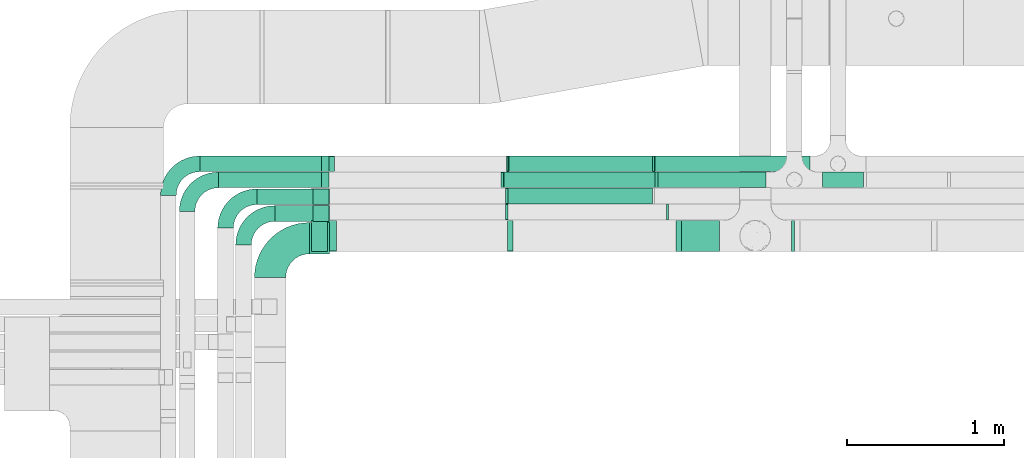
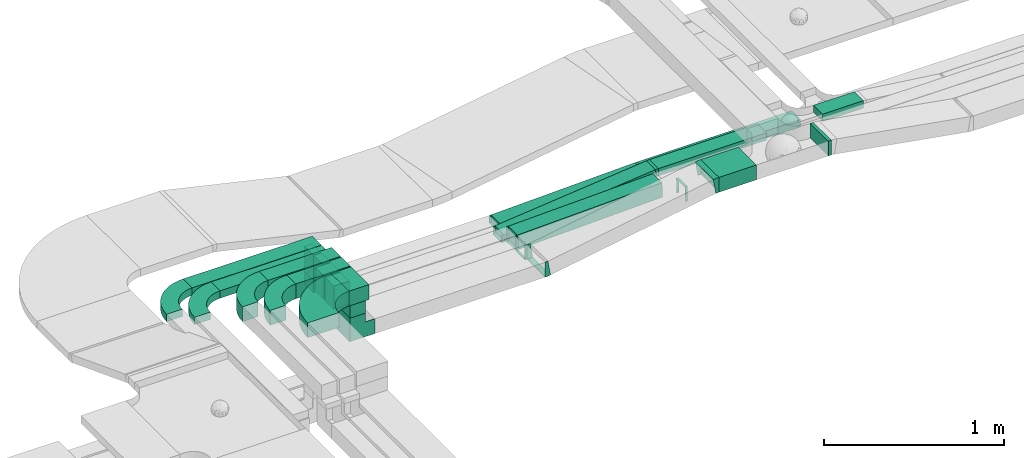
# One storey, part 8 of 28: 18 flow segments, 16 flow fittings.
"""IFC2X3 building model written with IfcOpenShell, lengths in millimetres."""

import ifcopenshell
import ifcopenshell.guid

model = None  # the IFC model being written
_history = None  # IfcOwnerHistory: only IFC2X3 demands one
_inside = {}  # id of a spatial element -> (the spatial element, [elements in it])
_under = {}  # id of a project, library or spatial element -> (it, [spatial elements below it])
_declared = {}  # id of a project -> (the project, [libraries it declares])
_typed = {}  # id of a type object -> (the type object, [elements of that type])
_made_of = {}  # id of a material, layer set ... -> (it, [elements and type objects made of it])


def new_model(schema):
    """Start an empty IFC model of exactly this schema.

    Asked for "IFC4X3", IfcOpenShell would pick the latest addendum, in which some entities
    have other attributes; the version numbers below select the first issue.
    IFC2X3 requires an IfcOwnerHistory on every rooted entity: one is made here for all.
    """
    global model, _history
    if schema == "IFC4X3":
        model = ifcopenshell.file(schema_version=(4, 3, 0, 0))
    else:
        model = ifcopenshell.file(schema=schema)
    _inside.clear()
    _under.clear()
    _declared.clear()
    _typed.clear()
    _made_of.clear()
    _history = None
    if model.schema == "IFC2X3":
        org = make("IfcOrganization", Name="unknown")
        user = make(
            "IfcPersonAndOrganization",
            ThePerson=make("IfcPerson", FamilyName="unknown"),
            TheOrganization=org,
        )
        app = make(
            "IfcApplication",
            ApplicationDeveloper=org,
            Version="unknown",
            ApplicationFullName="unknown",
            ApplicationIdentifier="unknown",
        )
        _history = make(
            "IfcOwnerHistory",
            OwningUser=user,
            OwningApplication=app,
            ChangeAction="ADDED",
            CreationDate=0,
        )
    return model


def make(cls, **values):
    """One entity of the class cls with the attributes given. An attribute that is None is left unset."""
    return model.create_entity(
        cls, **{name: value for name, value in values.items() if value is not None}
    )


def entity(cls, *values):
    """Any entity or typed value of the class cls, its attributes in the order of the schema. None: left unset."""
    e = model.create_entity(cls)
    for i, value in enumerate(values):
        if value is not None:
            e[i] = value
    return e


def rooted(cls, **values):
    """An entity with a GlobalId (a new one), such as an element, a storey or a relation."""
    return make(cls, GlobalId=ifcopenshell.guid.new(), OwnerHistory=_history, **values)


def si_unit(unit_type, name, prefix=None):
    """IfcSIUnit, for example si_unit("LENGTHUNIT", "METRE", prefix="MILLI")."""
    return make("IfcSIUnit", UnitType=unit_type, Prefix=prefix, Name=name)


def converted_unit(unit_type, name, factor, base, dimensions=None, offset=None):
    """IfcConversionBasedUnit, such as the inch: factor (a typed value) times the base unit."""
    return make(
        "IfcConversionBasedUnit"
        if offset is None
        else "IfcConversionBasedUnitWithOffset",
        ConversionOffset=offset,
        Dimensions=None
        if dimensions is None
        else entity("IfcDimensionalExponents", *dimensions),
        UnitType=unit_type,
        Name=name,
        ConversionFactor=make(
            "IfcMeasureWithUnit", ValueComponent=factor, UnitComponent=base
        ),
    )


def derived_unit(unit_type, elements):
    """IfcDerivedUnit: a product of units, each with its exponent."""
    return make(
        "IfcDerivedUnit",
        Elements=[
            make("IfcDerivedUnitElement", Unit=unit, Exponent=power)
            for unit, power in elements
        ],
        UnitType=unit_type,
    )


def assignment(units):
    """IfcUnitAssignment: the units of a project."""
    return None if units is None else make("IfcUnitAssignment", Units=units)


def point(xyz):
    """IfcCartesianPoint."""
    return None if xyz is None else make("IfcCartesianPoint", Coordinates=xyz)


def direction(xyz):
    """IfcDirection."""
    return None if xyz is None else make("IfcDirection", DirectionRatios=xyz)


def frame(location, z_axis=None, x_axis=None):
    """IfcAxis2Placement3D, a coordinate frame: its origin and axes. An axis left out is left unset."""
    return make(
        "IfcAxis2Placement3D",
        Location=point(location),
        Axis=direction(z_axis),
        RefDirection=direction(x_axis),
    )


def frame_2d(location, x_axis=None):
    """IfcAxis2Placement2D, a coordinate frame in the plane: its origin and x axis."""
    return make(
        "IfcAxis2Placement2D", Location=point(location), RefDirection=direction(x_axis)
    )


def origin():
    """The frame at (0, 0, 0) with its axes left unset."""
    return frame((0.0, 0.0, 0.0))


def origin_2d_with_axis():
    """The frame at (0, 0) in the plane with the x axis (1, 0) written out."""
    return frame_2d((0.0, 0.0), x_axis=(1.0, 0.0))


def place(relative_to, where):
    """IfcLocalPlacement: puts the frame where relative to a parent placement (None: the world)."""
    return make(
        "IfcLocalPlacement", PlacementRelTo=relative_to, RelativePlacement=where
    )


def context(
    kind, dimensions, precision=None, world=None, true_north=None, identifier=None
):
    """IfcGeometricRepresentationContext, for example the 3D "Model" context."""
    return make(
        "IfcGeometricRepresentationContext",
        ContextIdentifier=identifier,
        ContextType=kind,
        CoordinateSpaceDimension=dimensions,
        Precision=precision,
        WorldCoordinateSystem=world,
        TrueNorth=true_north,
    )


def subcontext(parent, identifier, kind, view, scale=None):
    """IfcGeometricRepresentationSubContext, for example "Body" below "Model"."""
    return make(
        "IfcGeometricRepresentationSubContext",
        ContextIdentifier=identifier,
        ContextType=kind,
        ParentContext=parent,
        TargetScale=scale,
        TargetView=view,
    )


def project(units=None, contexts=None):
    """IfcProject with its units and contexts."""
    return rooted(
        "IfcProject",
        Name="project",
        RepresentationContexts=contexts,
        UnitsInContext=assignment(units),
    )


def spatial(cls, under=None, at=None, **own):
    """A site, building, storey or space (cls), placed at a placement, below another one or the project."""
    s = rooted(cls, ObjectPlacement=at, **own)
    if under is not None:
        _under.setdefault(under.id(), (under, []))[1].append(s)
    return s


def polyline(points):
    """IfcPolyline through the points."""
    return make("IfcPolyline", Points=[point(p) for p in points])


def circle_curve(where, radius):
    """IfcCircle in the frame where."""
    return make("IfcCircle", Position=where, Radius=radius)


def parameter(value):
    """IfcParameterValue: where a trimmed curve begins or ends, as a parameter of its basis curve."""
    return model.create_entity("IfcParameterValue", value)


def trimmed(basis, trim1, trim2, sense, master):
    """IfcTrimmedCurve: the piece of a basis curve between two trims."""
    return make(
        "IfcTrimmedCurve",
        BasisCurve=basis,
        Trim1=trim1,
        Trim2=trim2,
        SenseAgreement=sense,
        MasterRepresentation=master,
    )


def segment(curve, same_sense, transition):
    """IfcCompositeCurveSegment."""
    return make(
        "IfcCompositeCurveSegment",
        Transition=transition,
        SameSense=same_sense,
        ParentCurve=curve,
    )


def composite_curve(segments, self_intersect=None):
    """IfcCompositeCurve: segments joined end to end."""
    return make("IfcCompositeCurve", Segments=segments, SelfIntersect=self_intersect)


def profile(cls, at=None, kind="AREA", **sizes):
    """A parametric profile (cls). Its sizes go by their IFC names, for example OverallWidth=200.0."""
    return make(cls, ProfileType=kind, Position=at, **sizes)


def rectangle(**sizes):
    """IfcRectangleProfileDef."""
    return profile("IfcRectangleProfileDef", **sizes)


def outline(outer, holes=None, kind="AREA"):
    """IfcArbitraryClosedProfileDef: a profile drawn as a closed curve; with holes, ...WithVoids."""
    if holes is None:
        return make("IfcArbitraryClosedProfileDef", ProfileType=kind, OuterCurve=outer)
    return make(
        "IfcArbitraryProfileDefWithVoids",
        ProfileType=kind,
        OuterCurve=outer,
        InnerCurves=holes,
    )


def extrude(swept, where, along, depth):
    """IfcExtrudedAreaSolid: the profile swept, set in the frame where, extruded along a direction by depth."""
    return make(
        "IfcExtrudedAreaSolid",
        SweptArea=swept,
        Position=where,
        ExtrudedDirection=direction(along),
        Depth=depth,
    )


def faces_of(points, faces, orient=None, outer=None):
    """IfcFace entities. A face is a list of loops; a loop is a list of indices into points, from 0.

    orient and outer hold one flag for each loop. By default every Orientation is true, the
    first loop of a face is its IfcFaceOuterBound and the others are IfcFaceBound.
    """
    made = []
    for i, loops in enumerate(faces):
        bounds = []
        for j, loop in enumerate(loops):
            is_outer = j == 0 if outer is None else outer[i][j]
            bounds.append(
                make(
                    "IfcFaceOuterBound" if is_outer else "IfcFaceBound",
                    Bound=make("IfcPolyLoop", Polygon=[points[k] for k in loop]),
                    Orientation=True if orient is None else orient[i][j],
                )
            )
        made.append(make("IfcFace", Bounds=bounds))
    return made


def faceted_brep(points, faces, orient=None, outer=None, voids=None):
    """IfcFacetedBrep: a solid bounded by flat faces; with voids (closed shells), ...WithVoids."""
    shared = [point(p) for p in points]
    hull = make("IfcClosedShell", CfsFaces=faces_of(shared, faces, orient, outer))
    if voids is None:
        return make("IfcFacetedBrep", Outer=hull)
    return make(
        "IfcFacetedBrepWithVoids",
        Outer=hull,
        Voids=[
            make(cls, CfsFaces=faces_of(shared, fs, o, b)) for cls, fs, o, b in voids
        ],
    )


def shape(context_of_items, identifier, shape_type, items):
    """IfcShapeRepresentation: the items that make up one representation, for example the "Body"."""
    return make(
        "IfcShapeRepresentation",
        ContextOfItems=context_of_items,
        RepresentationIdentifier=identifier,
        RepresentationType=shape_type,
        Items=items,
    )


def source(mapping_origin, context_of_items, identifier, shape_type, items):
    """IfcRepresentationMap: a shape defined once, which mapped items show again and again."""
    return make(
        "IfcRepresentationMap",
        MappingOrigin=mapping_origin,
        MappedRepresentation=shape(context_of_items, identifier, shape_type, items),
    )


def transform(
    local_origin,
    x_axis=None,
    y_axis=None,
    z_axis=None,
    scale=None,
    scale2=None,
    scale3=None,
    uniform=True,
):
    """IfcCartesianTransformationOperator3D, or its non-uniform kind. x_axis, y_axis, z_axis: its Axis1, 2, 3."""
    if uniform:
        return make(
            "IfcCartesianTransformationOperator3D",
            Axis1=direction(x_axis),
            Axis2=direction(y_axis),
            LocalOrigin=point(local_origin),
            Scale=scale,
            Axis3=direction(z_axis),
        )
    return make(
        "IfcCartesianTransformationOperator3DnonUniform",
        Axis1=direction(x_axis),
        Axis2=direction(y_axis),
        LocalOrigin=point(local_origin),
        Scale=scale,
        Axis3=direction(z_axis),
        Scale2=scale2,
        Scale3=scale3,
    )


def mapped(mapping_source, mapping_target):
    """IfcMappedItem: shows the shape of a source again, moved by a transform."""
    return make(
        "IfcMappedItem", MappingSource=mapping_source, MappingTarget=mapping_target
    )


def material(Name=None, Category=None):
    """IfcMaterial."""
    return make("IfcMaterial", Name=Name, Category=Category)


def made_of(thing, what):
    """Note that an element or type object is made of a material, layer set ...; save() writes the relation."""
    if what is not None:
        _made_of.setdefault(what.id(), (what, []))[1].append(thing)
    return thing


def type_object(cls, material=None, **own):
    """A type object (cls), such as IfcWallType, which elements share."""
    return made_of(rooted(cls, **own), material)


def type_shapes(of_type, sources):
    """Give a type object the sources (RepresentationMaps) that its elements show as mapped items."""
    of_type.RepresentationMaps = sources


def element(
    cls,
    number,
    at=None,
    inside=None,
    cuts=None,
    type_object=None,
    material=None,
    context=None,
    identifier="Body",
    shape_type=None,
    held_by="IfcProductDefinitionShape",
    body=None,
    shapes=None,
    **own,
):
    """One element of the class cls, such as IfcWall. Its Tag is "e" and its number.

    at: its placement. inside: the storey or other place that contains it. cuts: it is an
    opening in that element (IfcRelVoidsElement). A single representation is given by context,
    identifier, shape_type and body (its items); several are given by shapes. held_by: the class
    of the entity that holds the representations. save() writes the other relations.
    """
    e = rooted(cls, Tag="e%d" % number, ObjectPlacement=at, **own)
    if body is not None:
        shapes = [shape(context, identifier, shape_type, body)]
    if shapes is not None:
        e.Representation = make(held_by, Representations=shapes)
    if inside is not None:
        _inside.setdefault(inside.id(), (inside, []))[1].append(e)
    if cuts is not None:
        rooted(
            "IfcRelVoidsElement", RelatingBuildingElement=cuts, RelatedOpeningElement=e
        )
    if type_object is not None:
        _typed.setdefault(type_object.id(), (type_object, []))[1].append(e)
    return made_of(e, material)


def aggregate(whole, parts):
    """IfcRelAggregates: a whole, such as a stair, and the parts it consists of."""
    return rooted("IfcRelAggregates", RelatingObject=whole, RelatedObjects=parts)


def save(model, path):
    """Write the relations noted so far, then the file.

    IfcRelAggregates (storeys below a building ...), IfcRelContainedInSpatialStructure (elements
    in a storey), IfcRelDefinesByType, IfcRelAssociatesMaterial and IfcRelDeclares: one each for
    every whole, place, type object, material and project.
    """
    for whole, parts in _under.values():
        aggregate(whole, parts)
    for where, things in _inside.values():
        rooted(
            "IfcRelContainedInSpatialStructure",
            RelatedElements=things,
            RelatingStructure=where,
        )
    for kind, things in _typed.values():
        rooted("IfcRelDefinesByType", RelatedObjects=things, RelatingType=kind)
    for what, things in _made_of.values():
        rooted("IfcRelAssociatesMaterial", RelatedObjects=things, RelatingMaterial=what)
    for by, libraries in _declared.values():
        rooted("IfcRelDeclares", RelatingContext=by, RelatedDefinitions=libraries)
    model.write(path)


model = new_model("IFC2X3")

# Units and contexts
model_context = context("Model", 3, precision=0.01, world=origin(), true_north=direction((6.12303176911189e-17, 1.0)))
body_context = subcontext(model_context, "Body", "Model", "MODEL_VIEW")
ifc_project = project(units=[si_unit("LENGTHUNIT", "METRE", prefix="MILLI"), si_unit("AREAUNIT", "SQUARE_METRE"), si_unit("VOLUMEUNIT", "CUBIC_METRE"), converted_unit("PLANEANGLEUNIT", "DEGREE", entity("IfcRatioMeasure", 0.0174532925199433), si_unit("PLANEANGLEUNIT", "RADIAN"), dimensions=[0, 0, 0, 0, 0, 0, 0]), si_unit("MASSUNIT", "GRAM", prefix="KILO"), derived_unit("MASSDENSITYUNIT", [(si_unit("MASSUNIT", "GRAM", prefix="KILO"), 1), (si_unit("LENGTHUNIT", "METRE"), -3)]), derived_unit("MOMENTOFINERTIAUNIT", [(si_unit("LENGTHUNIT", "METRE"), 4)]), si_unit("TIMEUNIT", "SECOND"), si_unit("FREQUENCYUNIT", "HERTZ"), si_unit("THERMODYNAMICTEMPERATUREUNIT", "DEGREE_CELSIUS"), derived_unit("THERMALTRANSMITTANCEUNIT", [(si_unit("MASSUNIT", "GRAM", prefix="KILO"), 1), (si_unit("THERMODYNAMICTEMPERATUREUNIT", "KELVIN"), -1), (si_unit("TIMEUNIT", "SECOND"), -3)]), derived_unit("VOLUMETRICFLOWRATEUNIT", [(si_unit("LENGTHUNIT", "METRE"), 3), (si_unit("TIMEUNIT", "SECOND"), -1)]), derived_unit("MASSFLOWRATEUNIT", [(si_unit("MASSUNIT", "GRAM", prefix="KILO"), 1), (si_unit("TIMEUNIT", "SECOND"), -1)]), derived_unit("ROTATIONALFREQUENCYUNIT", [(si_unit("TIMEUNIT", "SECOND"), -1)]), si_unit("ELECTRICCURRENTUNIT", "AMPERE"), si_unit("ELECTRICVOLTAGEUNIT", "VOLT"), si_unit("POWERUNIT", "WATT"), si_unit("FORCEUNIT", "NEWTON", prefix="KILO"), si_unit("ILLUMINANCEUNIT", "LUX"), si_unit("LUMINOUSFLUXUNIT", "LUMEN"), si_unit("LUMINOUSINTENSITYUNIT", "CANDELA"), derived_unit("USERDEFINED", [(si_unit("MASSUNIT", "GRAM", prefix="KILO"), -1), (si_unit("LENGTHUNIT", "METRE"), -2), (si_unit("TIMEUNIT", "SECOND"), 3), (si_unit("LUMINOUSFLUXUNIT", "LUMEN"), 1)]), derived_unit("LINEARVELOCITYUNIT", [(si_unit("LENGTHUNIT", "METRE"), 1), (si_unit("TIMEUNIT", "SECOND"), -1)]), si_unit("PRESSUREUNIT", "PASCAL"), derived_unit("USERDEFINED", [(si_unit("LENGTHUNIT", "METRE"), -2), (si_unit("MASSUNIT", "GRAM", prefix="KILO"), 1), (si_unit("TIMEUNIT", "SECOND"), -2)]), derived_unit("LINEARFORCEUNIT", [(si_unit("MASSUNIT", "GRAM", prefix="KILO"), 1), (si_unit("LENGTHUNIT", "METRE"), 1), (si_unit("TIMEUNIT", "SECOND"), -2), (si_unit("LENGTHUNIT", "METRE"), -1)]), derived_unit("PLANARFORCEUNIT", [(si_unit("MASSUNIT", "GRAM", prefix="KILO"), 1), (si_unit("LENGTHUNIT", "METRE"), 1), (si_unit("TIMEUNIT", "SECOND"), -2), (si_unit("LENGTHUNIT", "METRE"), -2)])], contexts=[model_context])

# Site, building, storey
site_placement = place(None, origin())
site = spatial("IfcSite", under=ifc_project, at=site_placement, CompositionType="ELEMENT")
building_placement = place(site_placement, origin())
building = spatial("IfcBuilding", under=site, at=building_placement, CompositionType="ELEMENT")
storey_placement = place(building_placement, frame((0.0, 0.0, 4200.0)))
storey = spatial("IfcBuildingStorey", under=building, at=storey_placement, CompositionType="ELEMENT", Elevation=4200.0)

# Flow segments
cable_carrier_segment_type = type_object("IfcCableCarrierSegmentType", PredefinedType="CABLETRAYSEGMENT")
flow_segment_1_placement = place(storey_placement, frame((14113.43, 11443.79, 2904.06)))
element("IfcFlowSegment", 1, at=flow_segment_1_placement, inside=storey, type_object=cable_carrier_segment_type, context=body_context, shape_type="SweptSolid", body=[
    extrude(rectangle(XDim=240.106415937877, YDim=200.000000000002, at=origin_2d_with_axis()), frame((120.05, 100.0, 0.0), z_axis=(0.0, 0.0, 1.0), x_axis=(-1.0, 0.0, 0.0)), (0.0, 0.0, 1.0), 99.9999999999989),
])
flow_segment_2_placement = place(storey_placement, frame((14813.54, 11443.79, 2904.06)))
element("IfcFlowSegment", 2, at=flow_segment_2_placement, inside=storey, type_object=cable_carrier_segment_type, context=body_context, shape_type="SweptSolid", body=[
    extrude(rectangle(XDim=19.4517341104529, YDim=200.000000000002, at=origin_2d_with_axis()), frame((9.73, 100.0, 0.0)), (0.0, 0.0, 1.0), 99.9999999999989),
])
flow_segment_3_placement = place(storey_placement, frame((15013.07, 11851.53, 2820.0)))
element("IfcFlowSegment", 3, at=flow_segment_3_placement, inside=storey, type_object=cable_carrier_segment_type, context=body_context, shape_type="SweptSolid", body=[
    extrude(rectangle(XDim=261.171388914031, YDim=99.9999999999989, at=origin_2d_with_axis()), frame((130.59, 50.0, 0.0)), (0.0, 0.0, 1.0), 49.9999999999995),
])
flow_segment_4_placement = place(storey_placement, frame((13960.89, 11851.53, 2820.0)))
element("IfcFlowSegment", 4, at=flow_segment_4_placement, inside=storey, type_object=cable_carrier_segment_type, context=body_context, shape_type="SweptSolid", body=[
    extrude(rectangle(XDim=692.177239154652, YDim=99.9999999999989, at=origin_2d_with_axis()), frame((346.09, 50.0, 0.0), z_axis=(0.0, 0.0, 1.0), x_axis=(-1.0, 0.0, 0.0)), (0.0, 0.0, 1.0), 49.9999999999995),
])
flow_segment_5_placement = place(storey_placement, frame((13940.8, 11954.03, 2750.0)))
element("IfcFlowSegment", 5, at=flow_segment_5_placement, inside=storey, type_object=cable_carrier_segment_type, context=body_context, shape_type="SweptSolid", body=[
    extrude(rectangle(XDim=990.962450454234, YDim=99.9999999999989, at=origin_2d_with_axis()), frame((495.48, 50.0, 0.0), z_axis=(0.0, 0.0, 1.0), x_axis=(-1.0, 0.0, 0.0)), (0.0, 0.0, 1.0), 49.9999999999995),
])
flow_segment_6_placement = place(storey_placement, frame((11734.59, 11428.79, 2975.0)))
element("IfcFlowSegment", 6, at=flow_segment_6_placement, inside=storey, type_object=cable_carrier_segment_type, context=body_context, shape_type="SweptSolid", body=[
    extrude(rectangle(XDim=129.00000000001, YDim=200.000000000002, at=origin_2d_with_axis()), frame((64.5, 100.0, 0.0)), (0.0, 0.0, 1.0), 99.9999999999989),
])
flow_segment_7_placement = place(storey_placement, frame((11749.09, 11443.79, 2878.43)))
element("IfcFlowSegment", 7, at=flow_segment_7_placement, inside=storey, type_object=cable_carrier_segment_type, context=body_context, shape_type="SweptSolid", body=[
    extrude(rectangle(XDim=199.999999999998, YDim=99.9999999999989, at=origin_2d_with_axis()), frame((50.0, 100.0, 0.0), z_axis=(0.0, 0.0, 1.0), x_axis=(0.0, -1.0, 0.0)), (0.0, 0.0, 1.0), 96.5706856509242),
])
flow_segment_8_placement = place(storey_placement, frame((12998.9, 11748.96, 2718.66)))
element("IfcFlowSegment", 8, at=flow_segment_8_placement, inside=storey, type_object=cable_carrier_segment_type, context=body_context, shape_type="SweptSolid", body=[
    extrude(rectangle(XDim=99.9999999999996, YDim=99.9999999999989, at=frame_2d((0.0, 0.0), x_axis=(0.0, 1.0))), frame((1.69, 50.0, 49.97), z_axis=(0.999429384266034, 0.0, 0.0337772980804675), x_axis=(0.0, 1.0, 0.0)), (0.0, 0.0, 1.0), 927.191396822279),
])
flow_segment_9_placement = place(storey_placement, frame((12971.09, 11851.53, 2719.33)))
element("IfcFlowSegment", 9, at=flow_segment_9_placement, inside=storey, type_object=cable_carrier_segment_type, context=body_context, shape_type="SweptSolid", body=[
    extrude(rectangle(XDim=50.0000000000007, YDim=99.9999999999989, at=frame_2d((0.0, 0.0), x_axis=(0.0, 1.0))), frame((2.56, 50.0, 24.87), z_axis=(0.994745754755165, 0.0, 0.102376185690699), x_axis=(0.0, 1.0, 0.0)), (0.0, 0.0, 1.0), 976.772776710934),
])
flow_segment_10_placement = place(storey_placement, frame((13004.95, 11954.03, 2718.61)))
element("IfcFlowSegment", 10, at=flow_segment_10_placement, inside=storey, type_object=cable_carrier_segment_type, context=body_context, shape_type="SweptSolid", body=[
    extrude(rectangle(XDim=50.0000000000009, YDim=99.9999999999989, at=origin_2d_with_axis()), frame((0.84, 50.0, 24.99), z_axis=(0.999429384266034, 0.0, 0.0337772980804668), x_axis=(-0.0337772980804668, 0.0, 0.999429384266034)), (0.0, 0.0, 1.0), 923.681320339212),
])
flow_segment_11_placement = place(storey_placement, frame((11514.59, 11636.85, 2975.0)))
element("IfcFlowSegment", 11, at=flow_segment_11_placement, inside=storey, type_object=cable_carrier_segment_type, context=body_context, shape_type="SweptSolid", body=[
    extrude(rectangle(XDim=349.000000000007, YDim=99.9999999999989, at=origin_2d_with_axis()), frame((174.5, 50.0, 0.0)), (0.0, 0.0, 1.0), 100.000000000001),
])
flow_segment_12_placement = place(storey_placement, frame((11758.28, 11636.85, 2815.23)))
element("IfcFlowSegment", 12, at=flow_segment_12_placement, inside=storey, type_object=cable_carrier_segment_type, context=body_context, shape_type="SweptSolid", body=[
    extrude(rectangle(XDim=159.774248810582, YDim=99.9999998682313, at=frame_2d((0.0, 0.0), x_axis=(0.0, 1.0))), frame((0.0, 50.0, 79.89), z_axis=(1.0, 0.0, 5.13358561742023e-05), x_axis=(0.0, -1.0, 0.0)), (0.0, 5.13358561742023e-05, 1.0), 99.9999999999989),
])
flow_segment_13_placement = place(storey_placement, frame((11399.59, 11743.96, 2975.0)))
element("IfcFlowSegment", 13, at=flow_segment_13_placement, inside=storey, type_object=cable_carrier_segment_type, context=body_context, shape_type="SweptSolid", body=[
    extrude(rectangle(XDim=464.000000000027, YDim=99.9999999999989, at=origin_2d_with_axis()), frame((232.0, 50.0, 0.0)), (0.0, 0.0, 1.0), 100.000000000001),
])
flow_segment_14_placement = place(storey_placement, frame((11758.59, 11743.96, 2818.4)))
element("IfcFlowSegment", 14, at=flow_segment_14_placement, inside=storey, type_object=cable_carrier_segment_type, context=body_context, shape_type="SweptSolid", body=[
    extrude(rectangle(XDim=99.9999999999989, YDim=99.9999999999989, at=origin_2d_with_axis()), frame((50.0, 50.0, 0.0), z_axis=(0.0, 0.0, 1.0), x_axis=(0.0, 1.0, 0.0)), (0.0, 0.0, 1.0), 156.599999999993),
])
flow_segment_15_placement = place(storey_placement, frame((11154.59, 11851.53, 2975.0)))
element("IfcFlowSegment", 15, at=flow_segment_15_placement, inside=storey, type_object=cable_carrier_segment_type, context=body_context, shape_type="SweptSolid", body=[
    extrude(rectangle(XDim=706.005050633869, YDim=99.9999999999989, at=origin_2d_with_axis()), frame((353.0, 50.0, 0.0)), (0.0, 0.0, 1.0), 49.9999999999995),
])
flow_segment_16_placement = place(storey_placement, frame((11810.49, 11851.53, 2768.4)))
element("IfcFlowSegment", 16, at=flow_segment_16_placement, inside=storey, type_object=cable_carrier_segment_type, context=body_context, shape_type="SweptSolid", body=[
    extrude(rectangle(XDim=50.0000000000016, YDim=99.9999999999989, at=origin_2d_with_axis()), frame((25.0, 50.0, 0.0), z_axis=(0.0, 0.0, 1.0), x_axis=(-1.0, 0.0, 0.0)), (0.0, 0.0, 1.0), 206.599999999987),
])
flow_segment_17_placement = place(storey_placement, frame((11034.59, 11954.03, 2975.0)))
element("IfcFlowSegment", 17, at=flow_segment_17_placement, inside=storey, type_object=cable_carrier_segment_type, context=body_context, shape_type="SweptSolid", body=[
    extrude(rectangle(XDim=826.005050633864, YDim=99.9999999999989, at=origin_2d_with_axis()), frame((413.0, 50.0, 0.0)), (0.0, 0.0, 1.0), 49.9999999999984),
])
flow_segment_18_placement = place(storey_placement, frame((11810.49, 11954.03, 2803.4)))
element("IfcFlowSegment", 18, at=flow_segment_18_placement, inside=storey, type_object=cable_carrier_segment_type, context=body_context, shape_type="SweptSolid", body=[
    extrude(rectangle(XDim=50.0000000000016, YDim=99.9999999999989, at=origin_2d_with_axis()), frame((25.0, 50.0, 0.0), z_axis=(0.0, 0.0, 1.0), x_axis=(-1.0, 0.0, 0.0)), (0.0, 0.0, 1.0), 171.600000000021),
])

# Flow fittings
ifc_material = material()
cable_carrier_fitting_type_1 = type_object("IfcCableCarrierFittingType", PredefinedType="NOTDEFINED", material=ifc_material)
shared_shape_1 = source(origin(), body_context, "Body", "Brep", [
    faceted_brep([(-13.91, -50.0, 100.0), (-13.91, 50.0, 100.0), (-13.91, 50.0, 97.46), (-13.91, -47.46, 97.46), (-13.91, -47.46, -97.46), (-13.91, 50.0, -97.46), (-13.91, 50.0, -100.0), (-13.91, -50.0, -100.0), (22.13, -46.94, 100.0), (22.13, -46.94, -100.0), (5.29, 51.63, -100.0), (5.29, 51.63, -97.46), (21.7, -44.44, -97.46), (21.7, -44.44, 97.46), (5.29, 51.63, 97.46), (5.29, 51.63, 100.0), (4.24, -50.0, 100.0), (-4.24, 50.0, 100.0), (-4.24, 50.0, 97.46), (4.03, -47.46, 97.46), (4.03, -47.46, -97.46), (-4.24, 50.0, -97.46), (-4.24, 50.0, -100.0), (4.24, -50.0, -100.0)], [[[0, 1, 2, 3, 4, 5, 6, 7]], [[8, 9, 10, 11, 12, 13, 14, 15]], [[1, 0, 16, 8, 15, 17]], [[2, 1, 17, 18]], [[3, 2, 18, 14, 13, 19]], [[4, 3, 19, 20]], [[5, 4, 20, 12, 11, 21]], [[6, 5, 21, 22]], [[7, 6, 22, 10, 9, 23]], [[0, 7, 23, 16]], [[18, 17, 15, 14]], [[20, 19, 13, 12]], [[22, 21, 11, 10]], [[16, 23, 9, 8]]]),
])
type_shapes(cable_carrier_fitting_type_1, [shared_shape_1])
for number, where, z_axis, x_axis in (
    (19, (14099.53, 11543.79, 2954.06), (0.0, -1.0, 0.0), (-1.0, 0.0, 0.0)),
    (20, (13013.17, 11543.79, 2768.43), (0.0, 1.0, 0.0), (-0.98571328393655, 0.0, -0.168431950267824)),
):
    element("IfcFlowFitting", number, at=place(storey_placement, frame(where, z_axis=z_axis, x_axis=x_axis)), inside=storey, type_object=cable_carrier_fitting_type_1, material=ifc_material, context=body_context, shape_type="MappedRepresentation", body=[
        mapped(shared_shape_1, transform((0.0, 0.0, 0.0), scale=1.0)),
    ])
cable_carrier_fitting_type_2 = type_object("IfcCableCarrierFittingType", PredefinedType="NOTDEFINED", material=ifc_material)
shared_shape_2 = source(origin(), body_context, "Body", "Brep", [
    faceted_brep([(-110.0, -50.0, 100.0), (-110.0, 50.0, 100.0), (-110.0, 50.0, 97.46), (-110.0, -47.46, 97.46), (-110.0, -47.46, -97.46), (-110.0, 50.0, -97.46), (-110.0, 50.0, -100.0), (-110.0, -50.0, -100.0), (50.0, 110.0, 100.0), (50.0, 110.0, -100.0), (-50.0, 110.0, -100.0), (-50.0, 110.0, -97.46), (47.46, 110.0, -97.46), (47.46, 110.0, 97.46), (-50.0, 110.0, 97.46), (-50.0, 110.0, 100.0), (50.0, -50.0, 100.0), (-50.0, 50.0, 100.0), (-50.0, 50.0, 97.46), (47.46, -47.46, 97.46), (47.46, -47.46, -97.46), (-50.0, 50.0, -97.46), (-50.0, 50.0, -100.0), (50.0, -50.0, -100.0)], [[[0, 1, 2, 3, 4, 5, 6, 7]], [[8, 9, 10, 11, 12, 13, 14, 15]], [[1, 0, 16, 8, 15, 17]], [[2, 1, 17, 18]], [[3, 2, 18, 14, 13, 19]], [[4, 3, 19, 20]], [[5, 4, 20, 12, 11, 21]], [[6, 5, 21, 22]], [[7, 6, 22, 10, 9, 23]], [[0, 7, 23, 16]], [[18, 17, 15, 14]], [[20, 19, 13, 12]], [[22, 21, 11, 10]], [[16, 23, 9, 8]]]),
])
type_shapes(cable_carrier_fitting_type_2, [shared_shape_2])
flow_fitting_1_placement = place(storey_placement, frame((11799.09, 11543.79, 2768.43), z_axis=(0.0, 1.0, 0.0), x_axis=(-1.0, 0.0, 0.0)))
element("IfcFlowFitting", 21, at=flow_fitting_1_placement, inside=storey, type_object=cable_carrier_fitting_type_2, material=ifc_material, context=body_context, shape_type="MappedRepresentation", body=[
    mapped(shared_shape_2, transform((0.0, 0.0, 0.0), scale=1.0)),
])
cable_carrier_fitting_type_3 = type_object("IfcCableCarrierFittingType", PredefinedType="NOTDEFINED", material=ifc_material)
shared_shape_3 = source(origin(), body_context, "Body", "Brep", [
    faceted_brep([(-6.77, -50.0, 50.0), (-6.77, 50.0, 50.0), (-6.77, 50.0, 47.46), (-6.77, -47.46, 47.46), (-6.77, -47.46, -47.46), (-6.77, 50.0, -47.46), (-6.77, 50.0, -50.0), (-6.77, -50.0, -50.0), (8.46, -49.74, 50.0), (8.46, -49.74, -50.0), (5.08, 50.2, -50.0), (5.08, 50.2, -47.46), (8.37, -47.2, -47.46), (8.37, -47.2, 47.46), (5.08, 50.2, 47.46), (5.08, 50.2, 50.0), (0.84, -50.0, 50.0), (-0.84, 50.0, 50.0), (-0.84, 50.0, 47.46), (0.8, -47.46, 47.46), (0.8, -47.46, -47.46), (-0.84, 50.0, -47.46), (-0.84, 50.0, -50.0), (0.84, -50.0, -50.0)], [[[0, 1, 2, 3, 4, 5, 6, 7]], [[8, 9, 10, 11, 12, 13, 14, 15]], [[1, 0, 16, 8, 15, 17]], [[2, 1, 17, 18]], [[3, 2, 18, 14, 13, 19]], [[4, 3, 19, 20]], [[5, 4, 20, 12, 11, 21]], [[6, 5, 21, 22]], [[7, 6, 22, 10, 9, 23]], [[0, 7, 23, 16]], [[18, 17, 15, 14]], [[20, 19, 13, 12]], [[22, 21, 11, 10]], [[16, 23, 9, 8]]]),
])
type_shapes(cable_carrier_fitting_type_3, [shared_shape_3])
for number, where, z_axis, x_axis in (
    (22, (12994.03, 11696.85, 2765.23), (0.0, -1.0, 0.0), (1.0, 0.0, 0.0)),
    (23, (14022.96, 11696.85, 2800.0), (0.0, -1.0, 0.0), (-1.0, 0.0, 0.0)),
    (24, (12993.82, 11798.96, 2768.4), (0.0, -1.0, 0.0), (1.0, 0.0, 0.0)),
):
    element("IfcFlowFitting", number, at=place(storey_placement, frame(where, z_axis=z_axis, x_axis=x_axis)), inside=storey, type_object=cable_carrier_fitting_type_3, material=ifc_material, context=body_context, shape_type="MappedRepresentation", body=[
        mapped(shared_shape_3, transform((0.0, 0.0, 0.0), scale=1.0)),
    ])
cable_carrier_fitting_type_4 = type_object("IfcCableCarrierFittingType", PredefinedType="NOTDEFINED", material=ifc_material)
shared_shape_4 = source(origin(), body_context, "Body", "Brep", [
    faceted_brep([(-7.82, -25.0, 50.0), (-7.82, 25.0, 50.0), (-7.82, 25.0, 47.46), (-7.82, -22.46, 47.46), (-7.82, -22.46, -47.46), (-7.82, 25.0, -47.46), (-7.82, 25.0, -50.0), (-7.82, -25.0, -50.0), (10.34, -24.07, 50.0), (10.34, -24.07, -50.0), (5.22, 25.67, -50.0), (5.22, 25.67, -47.46), (10.08, -21.54, -47.46), (10.08, -21.54, 47.46), (5.22, 25.67, 47.46), (5.22, 25.67, 50.0), (1.28, -25.0, 50.0), (-1.28, 25.0, 50.0), (-1.28, 25.0, 47.46), (1.15, -22.46, 47.46), (1.15, -22.46, -47.46), (-1.28, 25.0, -47.46), (-1.28, 25.0, -50.0), (1.28, -25.0, -50.0)], [[[0, 1, 2, 3, 4, 5, 6, 7]], [[8, 9, 10, 11, 12, 13, 14, 15]], [[1, 0, 16, 8, 15, 17]], [[2, 1, 17, 18]], [[3, 2, 18, 14, 13, 19]], [[4, 3, 19, 20]], [[5, 4, 20, 12, 11, 21]], [[6, 5, 21, 22]], [[7, 6, 22, 10, 9, 23]], [[0, 7, 23, 16]], [[18, 17, 15, 14]], [[20, 19, 13, 12]], [[22, 21, 11, 10]], [[16, 23, 9, 8]]]),
])
type_shapes(cable_carrier_fitting_type_4, [shared_shape_4])
for number, where, z_axis, x_axis in (
    (25, (13953.07, 11901.53, 2845.0), (0.0, -1.0, 0.0), (-1.0, 0.0, 0.0)),
    (26, (12965.87, 11901.53, 2743.4), (0.0, 1.0, 0.0), (-0.994745754755166, 0.0, -0.102376185690695)),
):
    element("IfcFlowFitting", number, at=place(storey_placement, frame(where, z_axis=z_axis, x_axis=x_axis)), inside=storey, type_object=cable_carrier_fitting_type_4, material=ifc_material, context=body_context, shape_type="MappedRepresentation", body=[
        mapped(shared_shape_4, transform((0.0, 0.0, 0.0), scale=1.0)),
    ])
cable_carrier_fitting_type_5 = type_object("IfcCableCarrierFittingType", PredefinedType="NOTDEFINED", material=ifc_material)
shared_shape_5 = source(origin(), body_context, "Body", "Brep", [
    faceted_brep([(-5.93, -25.0, 50.0), (-5.93, 25.0, 50.0), (-5.93, 25.0, 47.46), (-5.93, -22.46, 47.46), (-5.93, -22.46, -47.46), (-5.93, 25.0, -47.46), (-5.93, 25.0, -50.0), (-5.93, -25.0, -50.0), (6.77, -24.79, 50.0), (6.77, -24.79, -50.0), (5.08, 25.19, -50.0), (5.08, 25.19, -47.46), (6.68, -22.25, -47.46), (6.68, -22.25, 47.46), (5.08, 25.19, 47.46), (5.08, 25.19, 50.0), (0.42, -25.0, 50.0), (-0.42, 25.0, 50.0), (-0.42, 25.0, 47.46), (0.38, -22.46, 47.46), (0.38, -22.46, -47.46), (-0.42, 25.0, -47.46), (-0.42, 25.0, -50.0), (0.42, -25.0, -50.0)], [[[0, 1, 2, 3, 4, 5, 6, 7]], [[8, 9, 10, 11, 12, 13, 14, 15]], [[1, 0, 16, 8, 15, 17]], [[2, 1, 17, 18]], [[3, 2, 18, 14, 13, 19]], [[4, 3, 19, 20]], [[5, 4, 20, 12, 11, 21]], [[6, 5, 21, 22]], [[7, 6, 22, 10, 9, 23]], [[0, 7, 23, 16]], [[18, 17, 15, 14]], [[20, 19, 13, 12]], [[22, 21, 11, 10]], [[16, 23, 9, 8]]]),
])
type_shapes(cable_carrier_fitting_type_5, [shared_shape_5])
flow_fitting_2_placement = place(storey_placement, frame((13934.87, 12004.03, 2775.0), z_axis=(0.0, -1.0, 0.0), x_axis=(-1.0, 0.0, 0.0)))
element("IfcFlowFitting", 27, at=flow_fitting_2_placement, inside=storey, type_object=cable_carrier_fitting_type_5, material=ifc_material, context=body_context, shape_type="MappedRepresentation", body=[
    mapped(shared_shape_5, transform((0.0, 0.0, 0.0), scale=1.0)),
])
cable_carrier_fitting_type_6 = type_object("IfcCableCarrierFittingType", PredefinedType="NOTDEFINED", material=ifc_material)
type_shapes(cable_carrier_fitting_type_6, [shared_shape_5])
flow_fitting_3_placement = place(storey_placement, frame((12999.87, 12004.03, 2743.4), z_axis=(0.0, 1.0, 0.0), x_axis=(-0.999429384266034, 0.0, -0.0337772980804659)))
element("IfcFlowFitting", 28, at=flow_fitting_3_placement, inside=storey, type_object=cable_carrier_fitting_type_6, material=ifc_material, context=body_context, shape_type="MappedRepresentation", body=[
    mapped(shared_shape_5, transform((0.0, 0.0, 0.0), scale=1.0)),
])
cable_carrier_fitting_type_7 = type_object("IfcCableCarrierFittingType", PredefinedType="NOTDEFINED", material=ifc_material)
shared_shape_6 = source(origin(), body_context, "Body", "Brep", [
    faceted_brep([(-60.0, -25.0, 50.0), (-60.0, 25.0, 50.0), (-60.0, 25.0, 47.46), (-60.0, -22.46, 47.46), (-60.0, -22.46, -47.46), (-60.0, 25.0, -47.46), (-60.0, 25.0, -50.0), (-60.0, -25.0, -50.0), (25.0, 60.0, 50.0), (25.0, 60.0, -50.0), (-25.0, 60.0, -50.0), (-25.0, 60.0, -47.46), (22.46, 60.0, -47.46), (22.46, 60.0, 47.46), (-25.0, 60.0, 47.46), (-25.0, 60.0, 50.0), (25.0, -25.0, 50.0), (-25.0, 25.0, 50.0), (-25.0, 25.0, 47.46), (22.46, -22.46, 47.46), (22.46, -22.46, -47.46), (-25.0, 25.0, -47.46), (-25.0, 25.0, -50.0), (25.0, -25.0, -50.0)], [[[0, 1, 2, 3, 4, 5, 6, 7]], [[8, 9, 10, 11, 12, 13, 14, 15]], [[1, 0, 16, 8, 15, 17]], [[2, 1, 17, 18]], [[3, 2, 18, 14, 13, 19]], [[4, 3, 19, 20]], [[5, 4, 20, 12, 11, 21]], [[6, 5, 21, 22]], [[7, 6, 22, 10, 9, 23]], [[0, 7, 23, 16]], [[18, 17, 15, 14]], [[20, 19, 13, 12]], [[22, 21, 11, 10]], [[16, 23, 9, 8]]]),
])
type_shapes(cable_carrier_fitting_type_7, [shared_shape_6])
flow_fitting_4_placement = place(storey_placement, frame((11835.49, 12004.03, 2743.4), z_axis=(0.0, 1.0, 0.0), x_axis=(-1.0, 0.0, 0.0)))
element("IfcFlowFitting", 29, at=flow_fitting_4_placement, inside=storey, type_object=cable_carrier_fitting_type_7, material=ifc_material, context=body_context, shape_type="MappedRepresentation", body=[
    mapped(shared_shape_6, transform((0.0, 0.0, 0.0), scale=1.0)),
])
cable_carrier_fitting_type_8 = type_object("IfcCableCarrierFittingType", Name="470_DKC_S5_Variable Angle Elbow 0-45:-", PredefinedType="NOTDEFINED", material=ifc_material)
shared_shape_7 = source(origin(), body_context, "Body", "SweptSolid", [
    extrude(outline(composite_curve([segment(polyline([(-125.75, -225.25), (-124.75, -225.25)]), True, "CONTINUOUS"), segment(trimmed(circle_curve(frame_2d((-124.75, 124.75), x_axis=(0.0, -1.0)), 350.0), [parameter(0.0)], [parameter(90.0000000000001)], True, "PARAMETER"), True, "CONTINUOUS"), segment(polyline([(225.25, 124.75), (225.25, 125.75)]), True, "CONTINUOUS"), segment(polyline([(225.25, 125.75), (25.25, 125.75)]), True, "CONTINUOUS"), segment(polyline([(25.25, 125.75), (25.25, 124.75)]), True, "CONTINUOUS"), segment(trimmed(circle_curve(frame_2d((-124.75, 124.75), x_axis=(0.0, -1.0)), 150.0), [parameter(0.0)], [parameter(90.0000000000001)], True, "PARAMETER"), False, "CONTINUOUS"), segment(polyline([(-124.75, -25.25), (-125.75, -25.25)]), True, "CONTINUOUS"), segment(polyline([(-125.75, -25.25), (-125.75, -225.25)]), True, "CONTINUOUS")], self_intersect=False)), frame((-125.25, 125.25, -50.0)), (0.0, 0.0, 1.0), 100.0),
])
type_shapes(cable_carrier_fitting_type_8, [shared_shape_7])
flow_fitting_5_placement = place(storey_placement, frame((11483.59, 11528.79, 3025.0), z_axis=(0.0, 0.0, 1.0), x_axis=(-1.0, 0.0, 0.0)))
element("IfcFlowFitting", 30, at=flow_fitting_5_placement, inside=storey, type_object=cable_carrier_fitting_type_8, material=ifc_material, Name="470_DKC_S5_Variable Angle Elbow 0-45:-", ObjectType="470_DKC_S5_Variable Angle Elbow 0-45:-", context=body_context, shape_type="MappedRepresentation", body=[
    mapped(shared_shape_7, transform((0.0, 0.0, 0.0), scale=1.0)),
])
cable_carrier_fitting_type_9 = type_object("IfcCableCarrierFittingType", Name="470_DKC_S5_Variable Angle Elbow 0-45:-", PredefinedType="NOTDEFINED", material=ifc_material)
shared_shape_8 = source(origin(), body_context, "Body", "SweptSolid", [
    extrude(outline(composite_curve([segment(polyline([(-100.75, -150.25), (-99.75, -150.25)]), True, "CONTINUOUS"), segment(trimmed(circle_curve(frame_2d((-99.75, 99.75), x_axis=(0.0, -1.0)), 250.0), [parameter(0.0)], [parameter(90.0000000000001)], True, "PARAMETER"), True, "CONTINUOUS"), segment(polyline([(150.25, 99.75), (150.25, 100.75)]), True, "CONTINUOUS"), segment(polyline([(150.25, 100.75), (50.25, 100.75)]), True, "CONTINUOUS"), segment(polyline([(50.25, 100.75), (50.25, 99.75)]), True, "CONTINUOUS"), segment(trimmed(circle_curve(frame_2d((-99.75, 99.75), x_axis=(0.0, -1.0)), 150.0), [parameter(0.0)], [parameter(90.0000000000001)], True, "PARAMETER"), False, "CONTINUOUS"), segment(polyline([(-99.75, -50.25), (-100.75, -50.25)]), True, "CONTINUOUS"), segment(polyline([(-100.75, -50.25), (-100.75, -150.25)]), True, "CONTINUOUS")], self_intersect=False)), frame((-100.25, 100.25, -25.0)), (0.0, 0.0, 1.0), 49.9999999999997),
])
type_shapes(cable_carrier_fitting_type_9, [shared_shape_8])
for number, where, z_axis, x_axis, name in (
    (31, (10953.59, 11901.53, 3000.0), (0.0, 0.0, 1.0), (-1.0, 0.0, 0.0), "470_DKC_S5_Variable Angle Elbow 0-45:-"),
    (32, (10833.59, 12004.03, 3000.0), (0.0, 0.0, 1.0), (-1.0, 0.0, 0.0), "470_DKC_S5_Variable Angle Elbow 0-45:-"),
):
    element("IfcFlowFitting", number, at=place(storey_placement, frame(where, z_axis=z_axis, x_axis=x_axis)), inside=storey, type_object=cable_carrier_fitting_type_9, material=ifc_material, Name=name, ObjectType="470_DKC_S5_Variable Angle Elbow 0-45:-", context=body_context, shape_type="MappedRepresentation", body=[
        mapped(shared_shape_8, transform((0.0, 0.0, 0.0), scale=1.0)),
    ])
cable_carrier_fitting_type_10 = type_object("IfcCableCarrierFittingType", Name="470_DKC_S5_Variable Angle Elbow 0-45:-", PredefinedType="NOTDEFINED", material=ifc_material)
shared_shape_9 = source(origin(), body_context, "Body", "SweptSolid", [
    extrude(outline(composite_curve([segment(polyline([(-100.75, -150.25), (-99.75, -150.25)]), True, "CONTINUOUS"), segment(trimmed(circle_curve(frame_2d((-99.75, 99.75), x_axis=(0.0, -1.0)), 250.0), [parameter(0.0)], [parameter(90.0000000000001)], True, "PARAMETER"), True, "CONTINUOUS"), segment(polyline([(150.25, 99.75), (150.25, 100.75)]), True, "CONTINUOUS"), segment(polyline([(150.25, 100.75), (50.25, 100.75)]), True, "CONTINUOUS"), segment(polyline([(50.25, 100.75), (50.25, 99.75)]), True, "CONTINUOUS"), segment(trimmed(circle_curve(frame_2d((-99.75, 99.75), x_axis=(0.0, -1.0)), 150.0), [parameter(0.0)], [parameter(90.0000000000001)], True, "PARAMETER"), False, "CONTINUOUS"), segment(polyline([(-99.75, -50.25), (-100.75, -50.25)]), True, "CONTINUOUS"), segment(polyline([(-100.75, -50.25), (-100.75, -150.25)]), True, "CONTINUOUS")], self_intersect=False)), frame((-100.25, 100.25, -50.0)), (0.0, 0.0, 1.0), 100.0),
])
type_shapes(cable_carrier_fitting_type_10, [shared_shape_9])
for number, where, z_axis, x_axis, name in (
    (33, (11313.59, 11686.85, 3025.0), (0.0, 0.0, 1.0), (-1.0, 0.0, 0.0), "470_DKC_S5_Variable Angle Elbow 0-45:-"),
    (34, (11198.59, 11793.96, 3025.0), (0.0, 0.0, 1.0), (-1.0, 0.0, 0.0), "470_DKC_S5_Variable Angle Elbow 0-45:-"),
):
    element("IfcFlowFitting", number, at=place(storey_placement, frame(where, z_axis=z_axis, x_axis=x_axis)), inside=storey, type_object=cable_carrier_fitting_type_10, material=ifc_material, Name=name, ObjectType="470_DKC_S5_Variable Angle Elbow 0-45:-", context=body_context, shape_type="MappedRepresentation", body=[
        mapped(shared_shape_9, transform((0.0, 0.0, 0.0), scale=1.0)),
    ])

save(model, "model.ifc")
